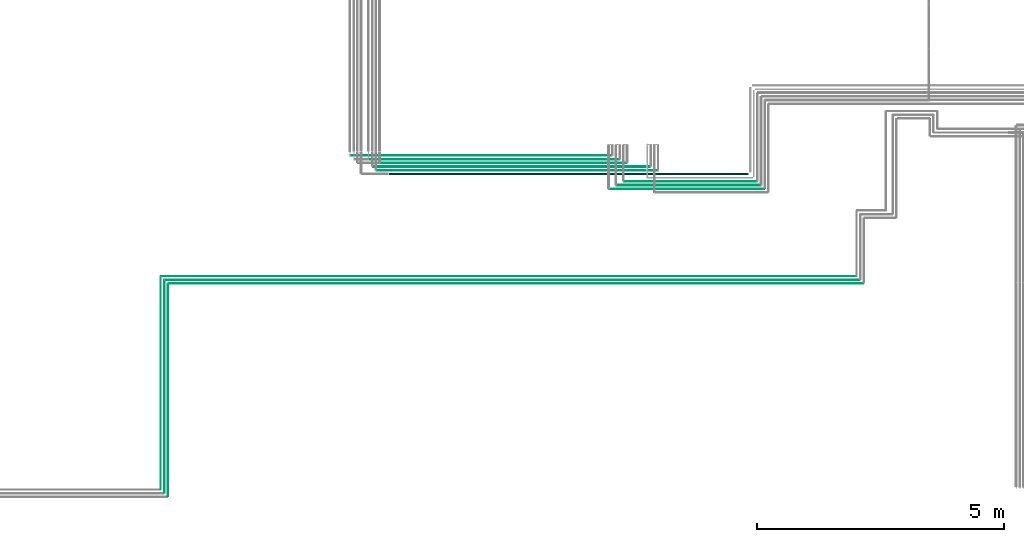
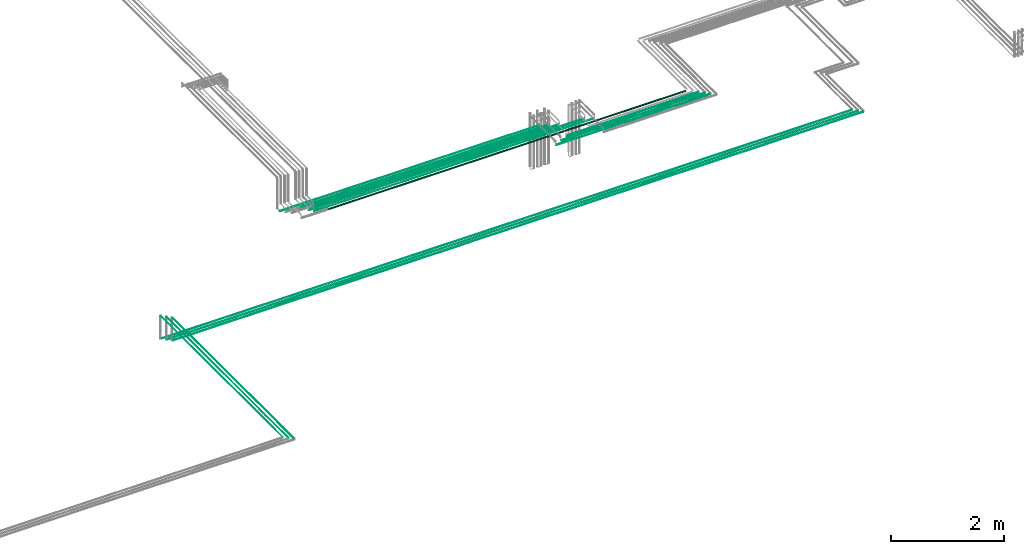
# One storey, part 3 of 65: 15 flow segments.
"""IFC2X3 building model written with IfcOpenShell, lengths in millimetres."""

from ifc_helpers import new_model, entity, si_unit, converted_unit, derived_unit, direction, frame, frame_2d, origin, origin_2d_with_axis, place, context, subcontext, project, spatial, circle, extrude, type_object, element, save


model = new_model("IFC2X3")

# Units and contexts
model_context = context("Model", 3, precision=0.01, world=origin(), true_north=direction((6.12303176911189e-17, 1.0)))
body_context = subcontext(model_context, "Body", "Model", "MODEL_VIEW")
ifc_project = project(units=[si_unit("LENGTHUNIT", "METRE", prefix="MILLI"), si_unit("AREAUNIT", "SQUARE_METRE"), si_unit("VOLUMEUNIT", "CUBIC_METRE"), converted_unit("PLANEANGLEUNIT", "DEGREE", entity("IfcRatioMeasure", 0.0174532925199433), si_unit("PLANEANGLEUNIT", "RADIAN"), dimensions=[0, 0, 0, 0, 0, 0, 0]), si_unit("MASSUNIT", "GRAM", prefix="KILO"), derived_unit("MASSDENSITYUNIT", [(si_unit("MASSUNIT", "GRAM", prefix="KILO"), 1), (si_unit("LENGTHUNIT", "METRE"), -3)]), derived_unit("MOMENTOFINERTIAUNIT", [(si_unit("LENGTHUNIT", "METRE"), 4)]), si_unit("TIMEUNIT", "SECOND"), si_unit("FREQUENCYUNIT", "HERTZ"), si_unit("THERMODYNAMICTEMPERATUREUNIT", "DEGREE_CELSIUS"), derived_unit("THERMALTRANSMITTANCEUNIT", [(si_unit("MASSUNIT", "GRAM", prefix="KILO"), 1), (si_unit("THERMODYNAMICTEMPERATUREUNIT", "KELVIN"), -1), (si_unit("TIMEUNIT", "SECOND"), -3)]), derived_unit("VOLUMETRICFLOWRATEUNIT", [(si_unit("LENGTHUNIT", "METRE"), 3), (si_unit("TIMEUNIT", "SECOND"), -1)]), derived_unit("MASSFLOWRATEUNIT", [(si_unit("MASSUNIT", "GRAM", prefix="KILO"), 1), (si_unit("TIMEUNIT", "SECOND"), -1)]), derived_unit("ROTATIONALFREQUENCYUNIT", [(si_unit("TIMEUNIT", "SECOND"), -1)]), si_unit("ELECTRICCURRENTUNIT", "AMPERE"), si_unit("ELECTRICVOLTAGEUNIT", "VOLT"), si_unit("POWERUNIT", "WATT"), si_unit("FORCEUNIT", "NEWTON", prefix="KILO"), si_unit("ILLUMINANCEUNIT", "LUX"), si_unit("LUMINOUSFLUXUNIT", "LUMEN"), si_unit("LUMINOUSINTENSITYUNIT", "CANDELA"), derived_unit("USERDEFINED", [(si_unit("MASSUNIT", "GRAM", prefix="KILO"), -1), (si_unit("LENGTHUNIT", "METRE"), -2), (si_unit("TIMEUNIT", "SECOND"), 3), (si_unit("LUMINOUSFLUXUNIT", "LUMEN"), 1)]), derived_unit("LINEARVELOCITYUNIT", [(si_unit("LENGTHUNIT", "METRE"), 1), (si_unit("TIMEUNIT", "SECOND"), -1)]), si_unit("PRESSUREUNIT", "PASCAL"), derived_unit("USERDEFINED", [(si_unit("LENGTHUNIT", "METRE"), -2), (si_unit("MASSUNIT", "GRAM", prefix="KILO"), 1), (si_unit("TIMEUNIT", "SECOND"), -2)]), derived_unit("LINEARFORCEUNIT", [(si_unit("MASSUNIT", "GRAM", prefix="KILO"), 1), (si_unit("LENGTHUNIT", "METRE"), 1), (si_unit("TIMEUNIT", "SECOND"), -2), (si_unit("LENGTHUNIT", "METRE"), -1)]), derived_unit("PLANARFORCEUNIT", [(si_unit("MASSUNIT", "GRAM", prefix="KILO"), 1), (si_unit("LENGTHUNIT", "METRE"), 1), (si_unit("TIMEUNIT", "SECOND"), -2), (si_unit("LENGTHUNIT", "METRE"), -2)])], contexts=[model_context])

# Site, building, storey
site_placement = place(None, frame((0.0, -0.00077364408347762, 0.0)))
site = spatial("IfcSite", under=ifc_project, at=site_placement, CompositionType="ELEMENT")
building_placement = place(site_placement, origin())
building = spatial("IfcBuilding", under=site, at=building_placement, CompositionType="ELEMENT")
storey_placement = place(building_placement, frame((0.0, 0.0, 19800.0)))
storey = spatial("IfcBuildingStorey", under=building, at=storey_placement, CompositionType="ELEMENT", Elevation=19800.0)

# Flow segments
pipe_segment_type = type_object("IfcPipeSegmentType", PredefinedType="NOTDEFINED")
flow_segment_1_placement = place(storey_placement, frame((42920.2717944076, 6740.90472776402, 2465.90472776409)))
element("IfcFlowSegment", 1, at=flow_segment_1_placement, inside=storey, type_object=pipe_segment_type, context=body_context, shape_type="SweptSolid", body=[
    extrude(circle(Radius=7.5, at=frame_2d((-2.05744754566695e-11, 0.0), x_axis=(1.0, 0.0))), frame((0.0, 9.09527223593694, 9.09527223591419), z_axis=(1.0, 0.0, 0.0), x_axis=(0.0, 1.0, 0.0)), (0.0, 0.0, 1.0), 2681.85034424299),
])
flow_segment_2_placement = place(storey_placement, frame((42766.2717944076, 6667.40472776402, 2467.40472776409)))
element("IfcFlowSegment", 2, at=flow_segment_2_placement, inside=storey, type_object=pipe_segment_type, context=body_context, shape_type="SweptSolid", body=[
    extrude(circle(Radius=6.0, at=frame_2d((-1.84087411980727e-11, 0.0), x_axis=(1.0, 0.0))), frame((0.0, 7.59527223593403, 7.59527223591454), z_axis=(1.0, 0.0, 0.0), x_axis=(0.0, 1.0, 0.0)), (0.0, 0.0, 1.0), 2914.85034424298),
])
flow_segment_3_placement = place(storey_placement, frame((42616.2717944076, 6592.40472776402, 2467.40472776409)))
element("IfcFlowSegment", 3, at=flow_segment_3_placement, inside=storey, type_object=pipe_segment_type, context=body_context, shape_type="SweptSolid", body=[
    extrude(circle(Radius=6.0, at=frame_2d((-2.38230768445646e-11, -4.33146851719357e-12), x_axis=(1.0, 0.0))), frame((0.0, 7.59527223593836, 7.5952722359102), z_axis=(1.0, 0.0, 0.0), x_axis=(0.0, 1.0, 0.0)), (0.0, 0.0, 1.0), 3139.850344243),
])
flow_segment_4_placement = place(storey_placement, frame((33684.1130695072, 4672.40472776407, 2542.40472776408)))
element("IfcFlowSegment", 4, at=flow_segment_4_placement, inside=storey, type_object=pipe_segment_type, context=body_context, shape_type="SweptSolid", body=[
    extrude(circle(Radius=6.0, at=origin_2d_with_axis()), frame((0.0, 7.59527223592482, 7.59527223591454), z_axis=(1.0, 0.0, 0.0), x_axis=(0.0, -1.0, 0.0)), (0.0, 0.0, 1.0), 14082.7132488306),
])
flow_segment_5_placement = place(storey_placement, frame((33605.113069507, 4749.40472776408, 2544.40472776408)))
element("IfcFlowSegment", 5, at=flow_segment_5_placement, inside=storey, type_object=pipe_segment_type, context=body_context, shape_type="SweptSolid", body=[
    extrude(circle(Radius=4.0, at=origin_2d_with_axis()), frame((0.0, 5.59527223592474, 5.59527223591499), z_axis=(1.0, 0.0, 0.0), x_axis=(0.0, -1.0, 0.0)), (0.0, 0.0, 1.0), 14090.713248831),
])
flow_segment_6_placement = place(storey_placement, frame((33530.113069507, 4824.40472776407, 2544.40472776408)))
element("IfcFlowSegment", 6, at=flow_segment_6_placement, inside=storey, type_object=pipe_segment_type, context=body_context, shape_type="SweptSolid", body=[
    extrude(circle(Radius=4.0, at=origin_2d_with_axis()), frame((0.0, 5.59527223615701, 5.59527223591499), z_axis=(1.0, 0.0, 0.0), x_axis=(0.0, -1.0, 0.0)), (0.0, 0.0, 1.0), 14090.7132488309),
])
flow_segment_7_placement = place(storey_placement, frame((33662.5177972714, 364.0, 3042.40472776409)))
element("IfcFlowSegment", 7, at=flow_segment_7_placement, inside=storey, type_object=pipe_segment_type, context=body_context, shape_type="SweptSolid", body=[
    extrude(circle(Radius=6.0, at=origin_2d_with_axis()), frame((7.59527223591454, 0.0, 7.59527223591454), z_axis=(0.0, 1.0, 0.0), x_axis=(-1.0, 0.0, 0.0)), (0.0, 0.0, 1.0), 4301.99999999989),
])
flow_segment_8_placement = place(storey_placement, frame((33589.5177972714, 435.0, 3044.40472776409)))
element("IfcFlowSegment", 8, at=flow_segment_8_placement, inside=storey, type_object=pipe_segment_type, context=body_context, shape_type="SweptSolid", body=[
    extrude(circle(Radius=4.0, at=origin_2d_with_axis()), frame((5.59527223591499, 0.0, 5.59527223591499), z_axis=(0.0, 1.0, 0.0), x_axis=(1.0, 0.0, 0.0)), (0.0, 0.0, 1.0), 4309.99999999993),
])
flow_segment_9_placement = place(storey_placement, frame((33514.5162722351, 510.0, 3044.4048201231)))
element("IfcFlowSegment", 9, at=flow_segment_9_placement, inside=storey, type_object=pipe_segment_type, context=body_context, shape_type="SweptSolid", body=[
    extrude(circle(Radius=4.0, at=origin_2d_with_axis()), frame((5.59527223591499, 0.0, 5.59527223591499), z_axis=(0.0, 1.0, 0.0), x_axis=(-1.0, 0.0, 0.0)), (0.0, 0.0, 1.0), 4310.00000000004),
])
flow_segment_10_placement = place(storey_placement, frame((37370.9284920929, 7269.40472776408, 2469.40472776414)))
element("IfcFlowSegment", 10, at=flow_segment_10_placement, inside=storey, type_object=pipe_segment_type, context=body_context, shape_type="SweptSolid", body=[
    extrude(circle(Radius=4.0, at=origin_2d_with_axis()), frame((0.0, 5.59527223591607, 5.59527223591499), z_axis=(1.0, 0.0, 0.0), x_axis=(0.0, -1.0, 0.0)), (0.0, 0.0, 1.0), 5296.34330231469),
])
flow_segment_11_placement = place(storey_placement, frame((37828.6463536, 7040.90472776404, 2465.90472776402)))
element("IfcFlowSegment", 11, at=flow_segment_11_placement, inside=storey, type_object=pipe_segment_type, context=body_context, shape_type="SweptSolid", body=[
    extrude(circle(Radius=7.5, at=frame_2d((-3.89832166547421e-11, 0.0), x_axis=(1.0, 0.0))), frame((0.0, 9.09527223595534, 9.09527223591419), z_axis=(1.0, 0.0, 0.0), x_axis=(0.0, 1.0, 0.0)), (0.0, 0.0, 1.0), 5610.62544080763),
])
flow_segment_12_placement = place(storey_placement, frame((37895.8112577491, 6969.40472776403, 2469.40472776401)))
element("IfcFlowSegment", 12, at=flow_segment_12_placement, inside=storey, type_object=pipe_segment_type, context=body_context, shape_type="SweptSolid", body=[
    extrude(circle(Radius=4.0, at=frame_2d((-4.22318180426373e-11, 0.0), x_axis=(1.0, 0.0))), frame((0.0, 5.5952722359583, 5.59527223591499), z_axis=(1.0, 0.0, 0.0), x_axis=(0.0, 1.0, 0.0)), (0.0, 0.0, 1.0), 5701.46053665849),
])
flow_segment_13_placement = place(storey_placement, frame((38148.142466198, 6880.90472776403, 2455.90472776409)))
element("IfcFlowSegment", 13, at=flow_segment_13_placement, inside=storey, type_object=pipe_segment_type, context=body_context, shape_type="SweptSolid", body=[
    extrude(circle(Radius=17.5, at=frame_2d((-3.89832166547421e-11, 0.0), x_axis=(1.0, 0.0))), frame((0.0, 19.0952722359552, 19.0952722359163), z_axis=(1.0, 0.0, 0.0), x_axis=(0.0, 1.0, 0.0)), (0.0, 0.0, 1.0), 7281.97967245257),
])
flow_segment_14_placement = place(storey_placement, frame((37743.0617129127, 7192.40472776405, 2467.40472776406)))
element("IfcFlowSegment", 14, at=flow_segment_14_placement, inside=storey, type_object=pipe_segment_type, context=body_context, shape_type="SweptSolid", body=[
    extrude(circle(Radius=6.0, at=origin_2d_with_axis()), frame((0.0, 7.59527223591778, 7.59527223591454), z_axis=(1.0, 0.0, 0.0), x_axis=(0.0, 1.0, 0.0)), (0.0, 0.0, 1.0), 5070.21008149491),
])
flow_segment_15_placement = place(storey_placement, frame((37968.6867073689, 7115.90472776404, 2465.90472776405)))
element("IfcFlowSegment", 15, at=flow_segment_15_placement, inside=storey, type_object=pipe_segment_type, context=body_context, shape_type="SweptSolid", body=[
    extrude(circle(Radius=7.5, at=frame_2d((1.08286712929839e-12, 0.0), x_axis=(1.0, 0.0))), frame((0.0, 9.09527223591744, 9.09527223591419), z_axis=(1.0, 0.0, 0.0), x_axis=(0.0, 1.0, 0.0)), (0.0, 0.0, 1.0), 4990.58508703869),
])

save(model, "model.ifc")
